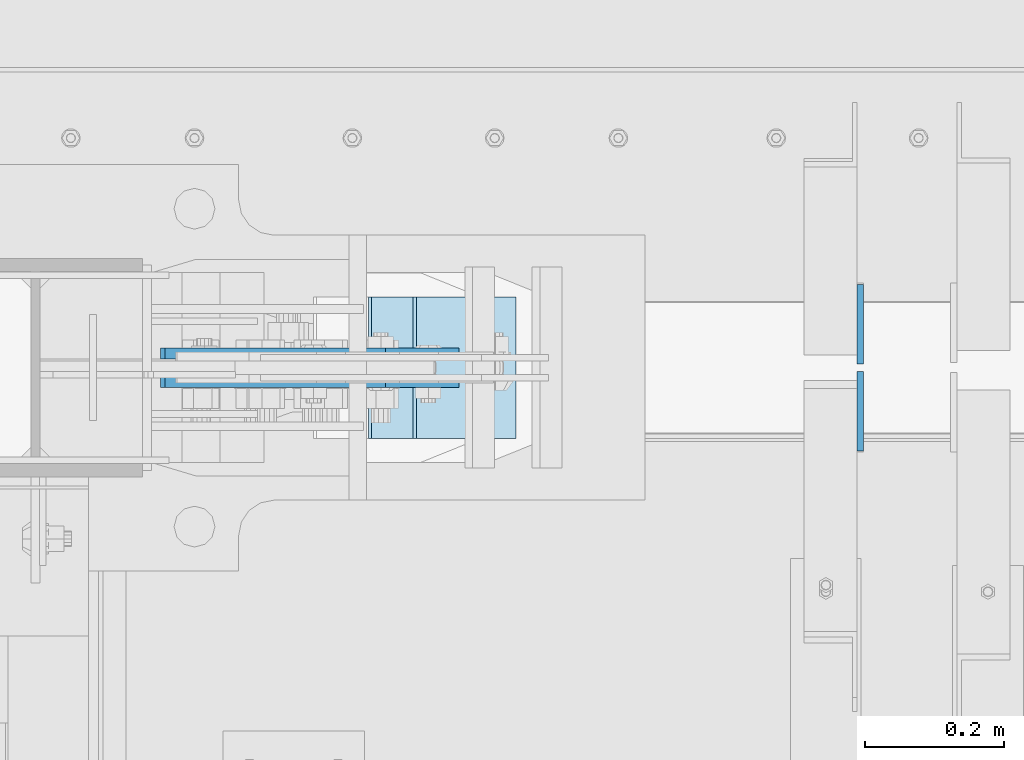
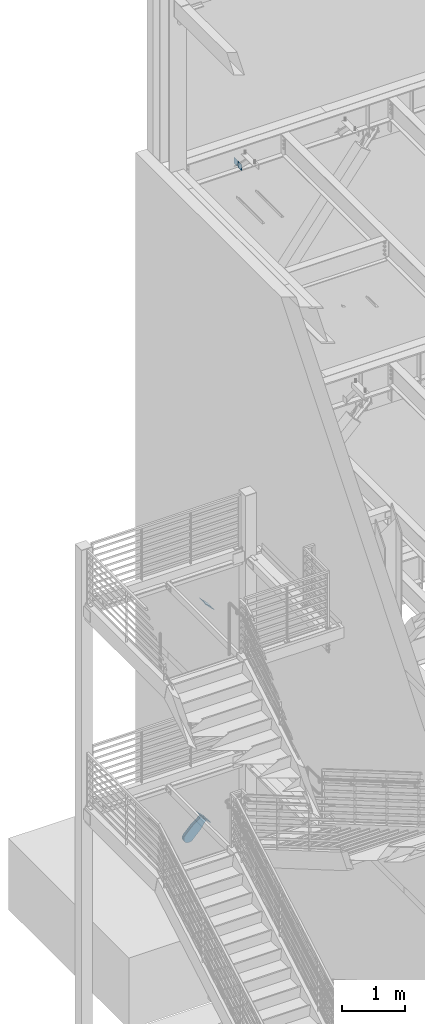
# One storey, part 1067 of 1179: 6 plates, 5 elements without a shape of their own.
"""IFC2X3 building model written with IfcOpenShell, lengths in millimetres."""

from ifc_helpers import new_model, si_unit, frame, origin_with_axes, place, context, subcontext, project, spatial, faceted_brep, material, type_object, element, aggregate, save


model = new_model("IFC2X3")

# Units and contexts
model_context = context("Model", 3, precision=1e-05, world=origin_with_axes())
body_context = subcontext(model_context, "Body", "Model", "MODEL_VIEW")
ifc_project = project(units=[si_unit("LENGTHUNIT", "METRE", prefix="MILLI"), si_unit("AREAUNIT", "SQUARE_METRE"), si_unit("VOLUMEUNIT", "CUBIC_METRE"), si_unit("MASSUNIT", "GRAM", prefix="KILO"), si_unit("TIMEUNIT", "SECOND"), si_unit("PLANEANGLEUNIT", "RADIAN"), si_unit("SOLIDANGLEUNIT", "STERADIAN"), si_unit("THERMODYNAMICTEMPERATUREUNIT", "DEGREE_CELSIUS"), si_unit("LUMINOUSINTENSITYUNIT", "LUMEN")], contexts=[model_context])

# Site, building, storey
site_placement = place(None, origin_with_axes())
site = spatial("IfcSite", under=ifc_project, at=site_placement, CompositionType="ELEMENT")
building_placement = place(site_placement, origin_with_axes())
building = spatial("IfcBuilding", under=site, at=building_placement, Name="Undefined", CompositionType="ELEMENT")
storey_placement = place(building_placement, origin_with_axes())
storey = spatial("IfcBuildingStorey", under=building, at=storey_placement, Name="Undefined", CompositionType="ELEMENT", Elevation=0.0)

# Assembly, plate
assembly_1_placement = place(storey_placement, origin_with_axes())
assembly_1 = element("IfcElementAssembly", 1, at=assembly_1_placement, inside=storey, Name="Plate", AssemblyPlace="NOTDEFINED", PredefinedType="RIGID_FRAME")
ifc_material = material(Name="STEEL/A36")
plate_type_1 = type_object("IfcPlateType", PredefinedType="NOTDEFINED")
plate_1_placement = place(assembly_1_placement, frame((1120.5412152882, 41097.2, 4370.52299178544), z_axis=(-0.705959813968941, 0.0, 0.708251890968841), x_axis=(0.0, 1.0, 0.0)))
plate_1 = element("IfcPlate", 2, at=plate_1_placement, type_object=plate_type_1, material=ifc_material, Name="Plate", context=body_context, shape_type="Brep", body=[
    faceted_brep([(0.0, -3.17500000000109, 0.0), (0.0, -3.17500000000291, 203.200000000368), (0.0, 3.17499999998836, 203.200000000361), (0.0, 3.17500000000109, 7.27595761418343e-12), (203.199999999997, -3.17500000000291, 203.200000000368), (203.199999999997, 3.17499999998836, 203.200000000361), (203.199999999997, -3.17499999999927, 3.63797880709171e-12), (203.199999999997, 3.17499999999382, -3.63797880709171e-12)], [[[0, 1, 2, 3]], [[1, 4, 5, 2]], [[4, 6, 7, 5]], [[6, 0, 3, 7]], [[5, 7, 3, 2]], [[6, 4, 1, 0]]]),
])
aggregate(assembly_1, [plate_1])

assembly_2_placement = place(storey_placement, origin_with_axes())
assembly_2 = element("IfcElementAssembly", 3, at=assembly_2_placement, inside=storey, Name="Plate", AssemblyPlace="NOTDEFINED", PredefinedType="RIGID_FRAME")
plate_2_placement = place(assembly_2_placement, frame((1058.54061926912, 41097.2, 283.975751989051), z_axis=(-0.717593116036186, 0.0, 0.696462576035121), x_axis=(0.0, 1.0, 0.0)))
plate_2 = element("IfcPlate", 4, at=plate_2_placement, type_object=plate_type_1, material=ifc_material, Name="Plate", context=body_context, shape_type="Brep", body=[
    faceted_brep([(0.0, -3.17500000000109, 0.0), (0.0, -3.17500000000291, 203.200000000368), (0.0, 3.17499999998836, 203.200000000361), (0.0, 3.17500000000109, 7.27595761418343e-12), (203.199999999997, -3.17500000000291, 203.200000000368), (203.199999999997, 3.17499999998836, 203.200000000361), (203.199999999997, -3.17499999999927, 3.63797880709171e-12), (203.199999999997, 3.17499999999382, -3.63797880709171e-12)], [[[0, 1, 2, 3]], [[1, 4, 5, 2]], [[4, 6, 7, 5]], [[6, 0, 3, 7]], [[5, 7, 3, 2]], [[6, 4, 1, 0]]]),
])
aggregate(assembly_2, [plate_2])

assembly_3_placement = place(storey_placement, origin_with_axes())
assembly_3 = element("IfcElementAssembly", 5, at=assembly_3_placement, inside=storey, AssemblyPlace="NOTDEFINED", PredefinedType="RIGID_FRAME")
plate_type_2 = type_object("IfcPlateType", PredefinedType="NOTDEFINED")
plate_3_placement = place(assembly_3_placement, frame((983.06039276668, 41219.4375, 246.620534371478), z_axis=(-0.717593116036186, 0.0, 0.696462576035121), x_axis=(0.696462576035121, 0.0, 0.717593116036186)))
plate_3 = element("IfcPlate", 6, at=plate_3_placement, type_object=plate_type_2, material=ifc_material, context=body_context, shape_type="Brep", body=[
    faceted_brep([(0.0, -7.9375, 0.0), (-101.600000000497, -7.9375, -21.7975798445477), (-101.600000000497, 7.9375, -21.7975798445477), (0.0, 7.9375, 0.0), (-320.921138851689, -7.9375, -21.7975798443877), (-320.921138851689, 7.9375, -21.7975798443877), (-357.371735784433, -7.9375, -14.5471053160727), (-357.371735784433, 7.9375, -14.5471053160727), (-388.273059759649, -7.9375, 6.10049924760824), (-388.273059759649, 7.9375, 6.10049924760824), (-408.920664323319, -7.9375, 37.0018232228431), (-408.920664323319, 7.9375, 37.0018232228431), (-416.171138851623, -7.9375, 73.4524201546446), (-416.171138851623, 7.9375, 73.4524201546446), (-408.920664323337, -7.9375, 109.903017087447), (-408.920664323337, 7.9375, 109.903017087447), (-388.273059759656, -7.9375, 140.804341062707), (-388.273059759656, 7.9375, 140.804341062707), (-357.3717357844, -7.9375, 161.451945626395), (-357.3717357844, 7.9375, 161.451945626395), (-320.921138851201, -7.9375, 168.702420154674), (-320.921138851201, 7.9375, 168.702420154674), (-101.600000000592, -7.9375, 168.702420154521), (-101.600000000592, 7.9375, 168.702420154521), (-8.00355337560177e-11, -7.9375, 146.904840309817), (-8.00355337560177e-11, 7.9375, 146.904840309817), (82.5499999998137, -7.9375, 146.90484031055), (82.5499999998137, 7.9375, 146.90484031055), (82.5500000000975, -7.9375, -6.91215973347425e-11), (82.5500000000975, 7.9375, -6.91215973347425e-11)], [[[0, 1, 2, 3]], [[1, 4, 5, 2]], [[4, 6, 7, 5]], [[6, 8, 9, 7]], [[8, 10, 11, 9]], [[10, 12, 13, 11]], [[12, 14, 15, 13]], [[14, 16, 17, 15]], [[16, 18, 19, 17]], [[18, 20, 21, 19]], [[20, 22, 23, 21]], [[22, 24, 25, 23]], [[24, 26, 27, 25]], [[26, 28, 29, 27]], [[28, 0, 3, 29]], [[5, 7, 9, 11, 13, 15, 17, 19, 21, 23, 25, 27, 29, 3, 2]], [[28, 26, 24, 22, 20, 18, 16, 14, 12, 10, 8, 6, 4, 1, 0]]]),
])
aggregate(assembly_3, [plate_3])

assembly_4_placement = place(storey_placement, origin_with_axes())
assembly_4 = element("IfcElementAssembly", 7, at=assembly_4_placement, inside=storey, AssemblyPlace="NOTDEFINED", PredefinedType="RIGID_FRAME")
plate_4_placement = place(assembly_4_placement, frame((983.06039276668, 41178.1625, 246.620534371478), z_axis=(-0.717593116036186, 0.0, 0.696462576035121), x_axis=(0.696462576035121, 0.0, 0.717593116036186)))
plate_4 = element("IfcPlate", 8, at=plate_4_placement, type_object=plate_type_2, material=ifc_material, context=body_context, shape_type="Brep", body=[
    faceted_brep([(0.0, -7.9375, 0.0), (-101.600000000497, -7.9375, -21.7975798445477), (-101.600000000497, 7.9375, -21.7975798445477), (0.0, 7.9375, 0.0), (-320.921138851689, -7.9375, -21.7975798443877), (-320.921138851689, 7.9375, -21.7975798443877), (-357.371735784433, -7.9375, -14.5471053160727), (-357.371735784433, 7.9375, -14.5471053160727), (-388.273059759649, -7.9375, 6.10049924760824), (-388.273059759649, 7.9375, 6.10049924760824), (-408.920664323319, -7.9375, 37.0018232228431), (-408.920664323319, 7.9375, 37.0018232228431), (-416.171138851623, -7.9375, 73.4524201546446), (-416.171138851623, 7.9375, 73.4524201546446), (-408.920664323337, -7.9375, 109.903017087447), (-408.920664323337, 7.9375, 109.903017087447), (-388.273059759656, -7.9375, 140.804341062707), (-388.273059759656, 7.9375, 140.804341062707), (-357.3717357844, -7.9375, 161.451945626395), (-357.3717357844, 7.9375, 161.451945626395), (-320.921138851201, -7.9375, 168.702420154674), (-320.921138851201, 7.9375, 168.702420154674), (-101.600000000592, -7.9375, 168.702420154521), (-101.600000000592, 7.9375, 168.702420154521), (-8.00355337560177e-11, -7.9375, 146.904840309817), (-8.00355337560177e-11, 7.9375, 146.904840309817), (82.5499999998137, -7.9375, 146.90484031055), (82.5499999998137, 7.9375, 146.90484031055), (82.5500000000975, -7.9375, -6.91215973347425e-11), (82.5500000000975, 7.9375, -6.91215973347425e-11)], [[[0, 1, 2, 3]], [[1, 4, 5, 2]], [[4, 6, 7, 5]], [[6, 8, 9, 7]], [[8, 10, 11, 9]], [[10, 12, 13, 11]], [[12, 14, 15, 13]], [[14, 16, 17, 15]], [[16, 18, 19, 17]], [[18, 20, 21, 19]], [[20, 22, 23, 21]], [[22, 24, 25, 23]], [[24, 26, 27, 25]], [[26, 28, 29, 27]], [[28, 0, 3, 29]], [[5, 7, 9, 11, 13, 15, 17, 19, 21, 23, 25, 27, 29, 3, 2]], [[28, 26, 24, 22, 20, 18, 16, 14, 12, 10, 8, 6, 4, 1, 0]]]),
])
aggregate(assembly_4, [plate_4])

# Assembly, plates
assembly_5_placement = place(storey_placement, origin_with_axes())
assembly_5 = element("IfcElementAssembly", 9, at=assembly_5_placement, inside=storey, Name="BEAM", AssemblyPlace="NOTDEFINED", PredefinedType="RIGID_FRAME")
plate_type_3 = type_object("IfcPlateType", PredefinedType="NOTDEFINED")
plate_5_placement = place(assembly_5_placement, frame((1617.66250000001, 41193.24375, 12690.4749987075), z_axis=(0.0, -0.707106781186506, 0.707106781186589), x_axis=(0.0, -0.70710678118659, -0.707106781186505)))
plate_5 = element("IfcPlate", 10, at=plate_5_placement, type_object=plate_type_3, material=ifc_material, Name="PLATE", context=body_context, shape_type="Brep", body=[
    faceted_brep([(0.0, -4.76249999999709, 0.0), (-67.3519210815575, -4.76250000000073, 67.3519210815502), (-67.3519210815575, 4.76250000000073, 67.3519210815502), (0.0, 4.76249999999709, 0.0), (13.4703845975746, -4.76250000000073, 148.174224853334), (13.4703845975746, 4.76250000000073, 148.174224853334), (94.2926864622132, -4.76250000000073, 67.3519210813465), (94.2926864622132, 4.76250000000073, 67.3519210813465), (26.9407683631525, -4.76249999999709, -6.18456397205591e-11), (26.9407683631525, 4.76249999999709, -6.18456397205591e-11)], [[[0, 1, 2, 3]], [[1, 4, 5, 2]], [[4, 6, 7, 5]], [[6, 8, 9, 7]], [[8, 0, 3, 9]], [[5, 7, 9, 3, 2]], [[8, 6, 4, 1, 0]]]),
])
plate_6_placement = place(assembly_5_placement, frame((1617.66250000001, 41204.35625, 12690.4749987075), z_axis=(0.0, 0.707106781186542, 0.707106781186553), x_axis=(0.0, 0.707106781186553, -0.707106781186542)))
plate_6 = element("IfcPlate", 11, at=plate_6_placement, type_object=plate_type_3, material=ifc_material, Name="PLATE", context=body_context, shape_type="Brep", body=[
    faceted_brep([(0.0, -4.76249999999709, 0.0), (-67.3519210815575, -4.76250000000073, 67.3519210815502), (-67.3519210815575, 4.76250000000073, 67.3519210815502), (0.0, 4.76249999999709, 0.0), (13.4703845975746, -4.76250000000073, 148.174224853334), (13.4703845975746, 4.76250000000073, 148.174224853334), (94.2926864622132, -4.76250000000073, 67.3519210813465), (94.2926864622132, 4.76250000000073, 67.3519210813465), (26.9407683631525, -4.76249999999709, -6.18456397205591e-11), (26.9407683631525, 4.76249999999709, -6.18456397205591e-11)], [[[0, 1, 2, 3]], [[1, 4, 5, 2]], [[4, 6, 7, 5]], [[6, 8, 9, 7]], [[8, 0, 3, 9]], [[5, 7, 9, 3, 2]], [[8, 6, 4, 1, 0]]]),
])
aggregate(assembly_5, [plate_5, plate_6])

save(model, "model.ifc")
